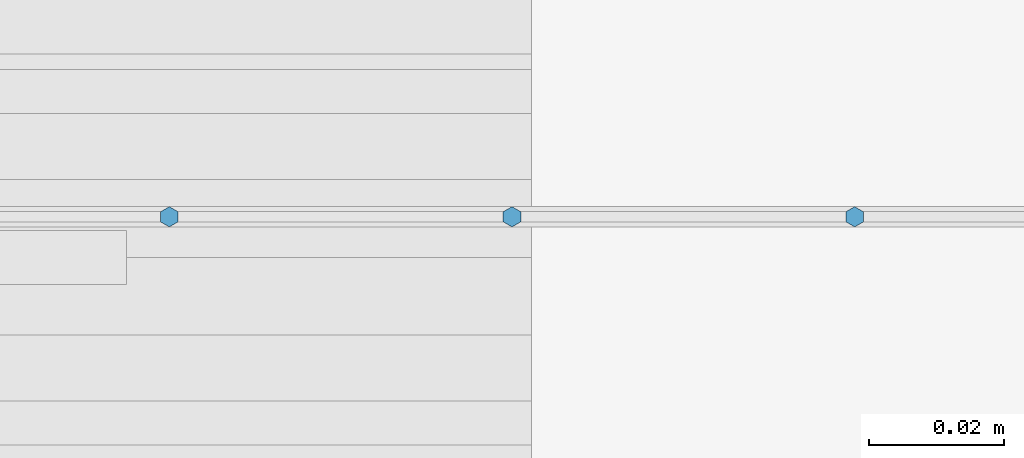
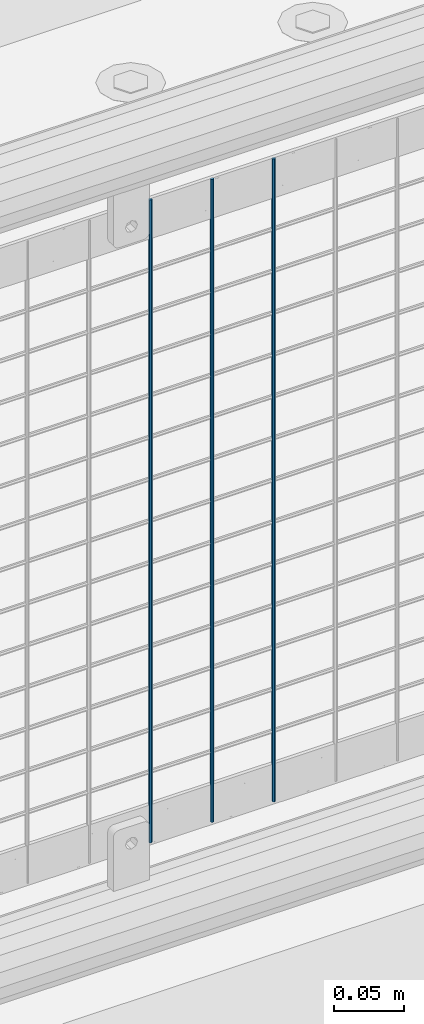
# One storey, part 75 of 242: 3 columns.
"""IFC2X3 building model written with IfcOpenShell, lengths in millimetres."""

from ifc_helpers import new_model, si_unit, frame, origin_with_axes, place, context, subcontext, project, spatial, faceted_brep, material, type_object, element, save


model = new_model("IFC2X3")

# Units and contexts
model_context = context("Model", 3, precision=1e-05, world=origin_with_axes())
body_context = subcontext(model_context, "Body", "Model", "MODEL_VIEW")
ifc_project = project(units=[si_unit("LENGTHUNIT", "METRE", prefix="MILLI"), si_unit("AREAUNIT", "SQUARE_METRE"), si_unit("VOLUMEUNIT", "CUBIC_METRE"), si_unit("MASSUNIT", "GRAM", prefix="KILO"), si_unit("TIMEUNIT", "SECOND"), si_unit("PLANEANGLEUNIT", "RADIAN"), si_unit("SOLIDANGLEUNIT", "STERADIAN"), si_unit("THERMODYNAMICTEMPERATUREUNIT", "DEGREE_CELSIUS"), si_unit("LUMINOUSINTENSITYUNIT", "LUMEN")], contexts=[model_context])

# Site, building, storey
site_placement = place(None, origin_with_axes())
site = spatial("IfcSite", under=ifc_project, at=site_placement, CompositionType="ELEMENT")
building_placement = place(site_placement, origin_with_axes())
building = spatial("IfcBuilding", under=site, at=building_placement, Name="Standard", CompositionType="ELEMENT")
storey_placement = place(building_placement, origin_with_axes())
storey = spatial("IfcBuildingStorey", under=building, at=storey_placement, Name="Undefined", CompositionType="ELEMENT", Elevation=0.0)

# Columns
ifc_material = material(Name="Misc_Undefined")
column_type = type_object("IfcColumnType", Name="D3", PredefinedType="NOTDEFINED")
for number, where, z_axis, x_axis in (
    (1, (-36342.07, -19329.5, 353.02), (-1.0, 0.0, 0.0), (0.0, 0.0, 1.0)),
    (2, (-36392.863, -19329.5, 353.02), (-1.0, 0.0, 0.0), (0.0, 0.0, 1.0)),
    (3, (-36443.656, -19329.5, 353.02), (-1.0, 0.0, 0.0), (0.0, 0.0, 1.0)),
):
    element("IfcColumn", number, at=place(storey_placement, frame(where, z_axis=z_axis, x_axis=x_axis)), inside=storey, type_object=column_type, material=ifc_material, ObjectType="D3", context=body_context, shape_type="Brep", body=[
        faceted_brep([(0.0, -1.50000000000364, 0.0), (-3.63797880709171e-12, -0.750000000003638, -1.29903810567669), (560.0, -0.75, -1.29903810567703), (560.0, -1.5, 0.0), (0.0, 0.749999999996362, -1.29903810567669), (560.0, 0.75, -1.29903810567703), (-3.63797880709171e-12, 1.49999999999636, 0.0), (560.0, 1.5, 0.0), (0.0, 0.749999999996362, 1.29903810567669), (560.0, 0.75, 1.29903810567703), (-3.63797880709171e-12, -0.750000000003638, 1.29903810567669), (560.0, -0.75, 1.29903810567703)], [[[0, 1, 2, 3]], [[1, 4, 5, 2]], [[4, 6, 7, 5]], [[6, 8, 9, 7]], [[8, 10, 11, 9]], [[10, 0, 3, 11]], [[5, 7, 9, 11, 3, 2]], [[10, 8, 6, 4, 1, 0]]]),
    ])

save(model, "model.ifc")
